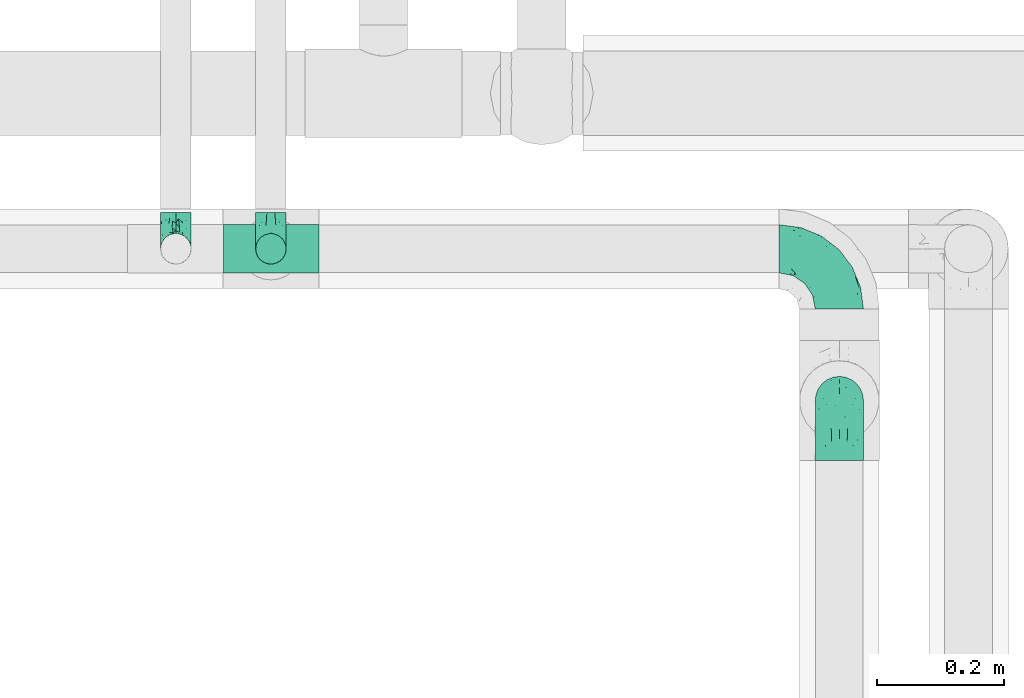
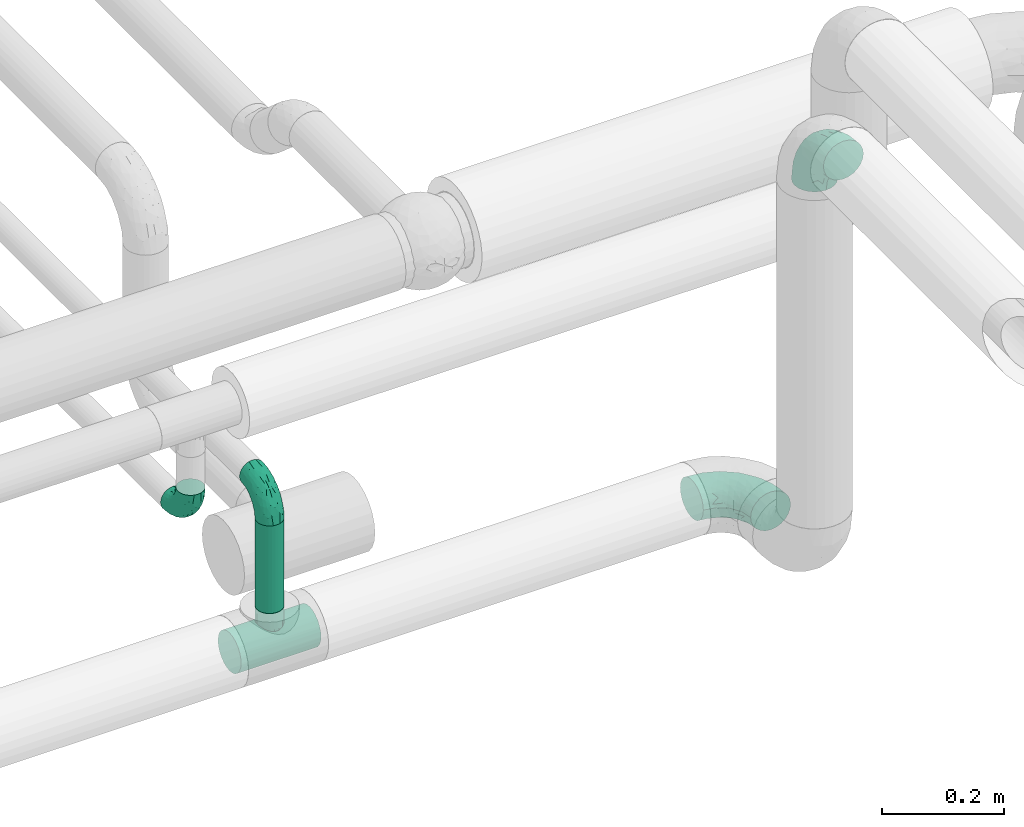
# One storey, part 557 of 824: 5 flow fittings, 1 flow segment.
"""IFC2X3 building model written with IfcOpenShell, lengths in millimetres."""

from ifc_helpers import new_model, entity, si_unit, converted_unit, derived_unit, direction, frame, origin, origin_2d_with_axis, place, context, subcontext, project, spatial, circle, extrude, faceted_brep, source, transform, mapped, material, type_object, type_shapes, element, save


model = new_model("IFC2X3")

# Units and contexts
model_context = context("Model", 3, precision=0.01, world=origin(), true_north=direction((6.12303176911189e-17, 1.0)))
body_context = subcontext(model_context, "Body", "Model", "MODEL_VIEW")
ifc_project = project(units=[si_unit("LENGTHUNIT", "METRE", prefix="MILLI"), si_unit("AREAUNIT", "SQUARE_METRE"), si_unit("VOLUMEUNIT", "CUBIC_METRE"), converted_unit("PLANEANGLEUNIT", "DEGREE", entity("IfcRatioMeasure", 0.0174532925199433), si_unit("PLANEANGLEUNIT", "RADIAN"), dimensions=[0, 0, 0, 0, 0, 0, 0]), si_unit("MASSUNIT", "GRAM", prefix="KILO"), derived_unit("MASSDENSITYUNIT", [(si_unit("MASSUNIT", "GRAM", prefix="KILO"), 1), (si_unit("LENGTHUNIT", "METRE"), -3)]), derived_unit("MOMENTOFINERTIAUNIT", [(si_unit("LENGTHUNIT", "METRE"), 4)]), si_unit("TIMEUNIT", "SECOND"), si_unit("FREQUENCYUNIT", "HERTZ"), si_unit("THERMODYNAMICTEMPERATUREUNIT", "DEGREE_CELSIUS"), derived_unit("THERMALTRANSMITTANCEUNIT", [(si_unit("MASSUNIT", "GRAM", prefix="KILO"), 1), (si_unit("THERMODYNAMICTEMPERATUREUNIT", "KELVIN"), -1), (si_unit("TIMEUNIT", "SECOND"), -3)]), derived_unit("VOLUMETRICFLOWRATEUNIT", [(si_unit("LENGTHUNIT", "METRE"), 3), (si_unit("TIMEUNIT", "SECOND"), -1)]), derived_unit("MASSFLOWRATEUNIT", [(si_unit("MASSUNIT", "GRAM", prefix="KILO"), 1), (si_unit("TIMEUNIT", "SECOND"), -1)]), derived_unit("ROTATIONALFREQUENCYUNIT", [(si_unit("TIMEUNIT", "SECOND"), -1)]), si_unit("ELECTRICCURRENTUNIT", "AMPERE"), si_unit("ELECTRICVOLTAGEUNIT", "VOLT"), si_unit("POWERUNIT", "WATT"), si_unit("FORCEUNIT", "NEWTON", prefix="KILO"), si_unit("ILLUMINANCEUNIT", "LUX"), si_unit("LUMINOUSFLUXUNIT", "LUMEN"), si_unit("LUMINOUSINTENSITYUNIT", "CANDELA"), derived_unit("USERDEFINED", [(si_unit("MASSUNIT", "GRAM", prefix="KILO"), -1), (si_unit("LENGTHUNIT", "METRE"), -2), (si_unit("TIMEUNIT", "SECOND"), 3), (si_unit("LUMINOUSFLUXUNIT", "LUMEN"), 1)]), derived_unit("LINEARVELOCITYUNIT", [(si_unit("LENGTHUNIT", "METRE"), 1), (si_unit("TIMEUNIT", "SECOND"), -1)]), si_unit("PRESSUREUNIT", "PASCAL"), derived_unit("USERDEFINED", [(si_unit("LENGTHUNIT", "METRE"), -2), (si_unit("MASSUNIT", "GRAM", prefix="KILO"), 1), (si_unit("TIMEUNIT", "SECOND"), -2)]), derived_unit("LINEARFORCEUNIT", [(si_unit("MASSUNIT", "GRAM", prefix="KILO"), 1), (si_unit("LENGTHUNIT", "METRE"), 1), (si_unit("TIMEUNIT", "SECOND"), -2), (si_unit("LENGTHUNIT", "METRE"), -1)]), derived_unit("PLANARFORCEUNIT", [(si_unit("MASSUNIT", "GRAM", prefix="KILO"), 1), (si_unit("LENGTHUNIT", "METRE"), 1), (si_unit("TIMEUNIT", "SECOND"), -2), (si_unit("LENGTHUNIT", "METRE"), -2)])], contexts=[model_context])

# Site, building, storey
site_placement = place(None, origin())
site = spatial("IfcSite", under=ifc_project, at=site_placement, CompositionType="ELEMENT")
building_placement = place(site_placement, origin())
building = spatial("IfcBuilding", under=site, at=building_placement, CompositionType="ELEMENT")
storey_placement = place(building_placement, frame((0.0, 0.0, 28200.0)))
storey = spatial("IfcBuildingStorey", under=building, at=storey_placement, CompositionType="ELEMENT", Elevation=28200.0)

# Flow segment
pipe_segment_type = type_object("IfcPipeSegmentType", PredefinedType="NOTDEFINED")
flow_segment_placement = place(storey_placement, frame((25740.61, 12044.41, 2667.0)))
element("IfcFlowSegment", 1, at=flow_segment_placement, inside=storey, type_object=pipe_segment_type, context=body_context, shape_type="SweptSolid", body=[
    extrude(circle(Radius=24.0, at=origin_2d_with_axis()), frame((25.6, 25.6, 0.0)), (0.0, 0.0, 1.0), 175.999999999995),
])

# Flow fittings
ifc_material = material()
pipe_fitting_type_1 = type_object("IfcPipeFittingType", PredefinedType="NOTDEFINED", material=ifc_material)
shared_shape_1 = source(origin(), body_context, "Body", "Brep", [
    faceted_brep([(-76.0, 9.85, -36.75), (-76.0, 0.0, -38.05), (-76.0, -9.85, -36.75), (-76.0, -19.03, -32.95), (-76.0, -26.91, -26.91), (-76.0, -32.95, -19.03), (-76.0, -36.75, -9.85), (-76.0, -38.05, 0.0), (-76.0, -36.75, 9.85), (-76.0, -32.95, 19.02), (-76.0, -26.91, 26.91), (-76.0, -19.03, 32.95), (-76.0, -9.85, 36.75), (-76.0, 0.0, 38.05), (-76.0, 9.85, 36.75), (-76.0, 19.02, 32.95), (-76.0, 26.91, 26.91), (-76.0, 32.95, 19.02), (-76.0, 36.75, 9.85), (-76.0, 38.05, 0.0), (-76.0, 36.75, -9.85), (-76.0, 32.95, -19.03), (-76.0, 26.91, -26.91), (-76.0, 19.02, -32.95), (76.0, 26.91, -26.91), (76.0, 32.95, -19.03), (76.0, 36.75, -9.85), (76.0, 38.05, 0.0), (76.0, 36.75, 9.85), (76.0, 32.95, 19.02), (76.0, 26.91, 26.91), (76.0, 19.02, 32.95), (76.0, 9.85, 36.75), (76.0, 0.0, 38.05), (76.0, -9.85, 36.75), (76.0, -19.03, 32.95), (76.0, -26.91, 26.91), (76.0, -32.95, 19.02), (76.0, -36.75, 9.85), (76.0, -38.05, 0.0), (76.0, -36.75, -9.85), (76.0, -32.95, -19.03), (76.0, -26.91, -26.91), (76.0, -19.03, -32.95), (76.0, -9.85, -36.75), (76.0, 0.0, -38.05), (76.0, 9.85, -36.75), (76.0, 19.02, -32.95), (22.62, -37.1, 8.45), (23.39, -37.58, 4.22), (24.15, -38.05, 0.0), (18.42, -34.7, 15.61), (4.31, -29.72, 23.76), (12.18, -31.83, 20.86), (8.24, -30.77, 22.31), (-24.15, -38.05, 0.0), (-23.39, -37.58, 4.22), (-22.63, -37.1, 8.44), (-18.43, -34.7, 15.61), (-12.18, -31.83, 20.85), (-4.31, -29.72, 23.76), (0.0, -29.72, 23.76), (4.31, -29.72, -23.76), (12.18, -31.83, -20.86), (8.24, -30.77, -22.31), (18.42, -34.7, -15.61), (22.62, -37.1, -8.45), (23.39, -37.58, -4.22), (-4.31, -29.72, -23.76), (-12.18, -31.83, -20.85), (-18.43, -34.7, -15.61), (0.0, -29.72, -23.76), (-22.63, -37.1, -8.44), (-23.39, -37.58, -4.22), (0.0, -67.0, -24.15), (6.25, -67.0, -23.33), (12.08, -67.0, -20.91), (17.08, -67.0, -17.08), (20.91, -67.0, -12.08), (23.33, -67.0, -6.25), (24.15, -67.0, 0.0), (23.33, -67.0, 6.25), (20.91, -67.0, 12.07), (17.08, -67.0, 17.08), (12.08, -67.0, 20.91), (6.25, -67.0, 23.33), (0.0, -67.0, 24.15), (-6.25, -67.0, 23.33), (-12.07, -67.0, 20.91), (-17.08, -67.0, 17.08), (-20.91, -67.0, 12.07), (-23.33, -67.0, 6.25), (-24.15, -67.0, 0.0), (-23.33, -67.0, -6.25), (-20.91, -67.0, -12.08), (-17.08, -67.0, -17.08), (-12.07, -67.0, -20.91), (-6.25, -67.0, -23.33)], [[[0, 1, 2, 3, 4, 5, 6, 7, 8, 9, 10, 11, 12, 13, 14, 15, 16, 17, 18, 19, 20, 21, 22, 23]], [[24, 25, 26, 27, 28, 29, 30, 31, 32, 33, 34, 35, 36, 37, 38, 39, 40, 41, 42, 43, 44, 45, 46, 47]], [[39, 38, 48]], [[39, 48, 49, 50]], [[38, 51, 48]], [[37, 36, 52]], [[53, 51, 37]], [[37, 52, 54, 53]], [[36, 10, 52]], [[37, 51, 38]], [[7, 55, 56, 57]], [[8, 7, 57]], [[57, 58, 8]], [[59, 60, 9]], [[59, 9, 58]], [[9, 60, 10]], [[58, 9, 8]], [[10, 60, 61, 52]], [[36, 35, 11, 10]], [[13, 12, 34, 33]], [[12, 11, 35, 34]], [[14, 13, 33, 32]], [[29, 28, 18, 17]], [[16, 15, 31, 30]], [[17, 16, 30, 29]], [[32, 31, 15, 14]], [[19, 18, 28, 27]], [[26, 25, 21, 20]], [[25, 24, 22, 21]], [[27, 26, 20, 19]], [[45, 44, 2, 1]], [[0, 23, 47, 46]], [[1, 0, 46, 45]], [[24, 47, 23, 22]], [[3, 2, 44, 43]], [[43, 42, 4, 3]], [[42, 41, 62]], [[41, 63, 64, 62]], [[41, 65, 63]], [[42, 62, 4]], [[40, 39, 66]], [[66, 65, 40]], [[39, 50, 67, 66]], [[40, 65, 41]], [[68, 69, 5]], [[5, 4, 68]], [[69, 70, 5]], [[4, 62, 71, 68]], [[70, 72, 6]], [[72, 7, 6]], [[7, 72, 73, 55]], [[70, 6, 5]], [[74, 75, 76, 77, 78, 79, 80, 81, 82, 83, 84, 85, 86, 87, 88, 89, 90, 91, 92, 93, 94, 95, 96, 97]], [[56, 92, 91]], [[86, 60, 87]], [[59, 89, 88]], [[84, 54, 85]], [[49, 80, 50]], [[59, 88, 87]], [[49, 48, 81]], [[91, 57, 56]], [[55, 92, 56]], [[57, 91, 90]], [[57, 90, 58]], [[89, 58, 90]], [[89, 59, 58]], [[87, 60, 59]], [[86, 52, 61, 60]], [[84, 53, 54]], [[83, 53, 84]], [[48, 82, 81]], [[83, 82, 51]], [[52, 86, 85]], [[54, 52, 85]], [[53, 83, 51]], [[51, 82, 48]], [[80, 49, 81]], [[79, 67, 80]], [[77, 65, 78]], [[64, 76, 75]], [[79, 66, 67]], [[78, 66, 79]], [[63, 77, 76]], [[67, 50, 80]], [[66, 78, 65]], [[75, 62, 64]], [[63, 65, 77]], [[74, 68, 71, 62]], [[74, 62, 75]], [[73, 92, 55]], [[69, 97, 96]], [[73, 72, 93]], [[95, 69, 96]], [[72, 94, 93]], [[95, 94, 70]], [[68, 74, 97]], [[97, 69, 68]], [[69, 95, 70]], [[70, 94, 72]], [[92, 73, 93]], [[64, 63, 76]]]),
])
type_shapes(pipe_fitting_type_1, [shared_shape_1])
flow_fitting_placement = place(storey_placement, frame((25766.21, 12070.0, 2600.0), z_axis=(0.0, 1.0, 0.0), x_axis=(1.0, 0.0, 0.0)))
element("IfcFlowFitting", 2, at=flow_fitting_placement, inside=storey, type_object=pipe_fitting_type_1, material=ifc_material, context=body_context, shape_type="MappedRepresentation", body=[
    mapped(shared_shape_1, transform((0.0, 0.0, 0.0), scale=1.0)),
])
pipe_fitting_type_2 = type_object("IfcPipeFittingType", PredefinedType="NOTDEFINED", material=ifc_material)
shared_shape_2 = source(origin(), body_context, "Body", "Brep", [
    faceted_brep([(-57.0, 12.07, -20.91), (-57.0, 6.25, -23.33), (-57.0, 0.0, -24.15), (-57.0, -6.25, -23.33), (-57.0, -12.08, -20.91), (-57.0, -17.08, -17.08), (-57.0, -20.91, -12.08), (-57.0, -23.33, -6.25), (-57.0, -24.15, 0.0), (-57.0, -23.33, 6.25), (-57.0, -20.91, 12.07), (-57.0, -17.08, 17.08), (-57.0, -12.08, 20.91), (-57.0, -6.25, 23.33), (-57.0, 0.0, 24.15), (-57.0, 6.25, 23.33), (-57.0, 12.07, 20.91), (-57.0, 17.08, 17.08), (-57.0, 20.91, 12.07), (-57.0, 23.33, 6.25), (-57.0, 24.15, 0.0), (-57.0, 23.33, -6.25), (-57.0, 20.91, -12.08), (-57.0, 17.08, -17.08), (0.0, 57.0, -24.15), (-6.25, 57.0, -23.33), (-12.07, 57.0, -20.91), (-17.08, 57.0, -17.08), (-20.91, 57.0, -12.08), (-23.33, 57.0, -6.25), (-24.15, 57.0, 0.0), (-23.33, 57.0, 6.25), (-20.91, 57.0, 12.07), (-17.08, 57.0, 17.08), (-12.07, 57.0, 20.91), (-6.25, 57.0, 23.33), (0.0, 57.0, 24.15), (6.25, 57.0, 23.33), (12.08, 57.0, 20.91), (17.08, 57.0, 17.08), (20.91, 57.0, 12.07), (23.33, 57.0, 6.25), (24.15, 57.0, 0.0), (23.33, 57.0, -6.25), (20.91, 57.0, -12.08), (17.08, 57.0, -17.08), (12.08, 57.0, -20.91), (6.25, 57.0, -23.33), (14.9, 21.14, 6.17), (13.61, 24.64, 12.48), (6.23, 8.95, 8.98), (-41.47, -21.06, 0.0), (-41.92, -18.38, 13.72), (-24.64, -13.61, 12.48), (-37.37, -13.24, 18.15), (-6.8, -4.93, 8.18), (-21.76, -15.19, 6.22), (-12.78, -9.18, 0.0), (-37.73, -20.51, 7.75), (-7.38, 7.38, 20.24), (-23.37, -4.26, 20.42), (-11.9, -3.19, 15.86), (-42.14, -8.7, 21.82), (13.24, 37.37, 18.15), (9.33, 23.53, 16.85), (4.26, 23.37, 20.42), (2.77, 10.92, 15.55), (-29.46, 0.91, 23.52), (-44.13, 20.56, 15.69), (-39.25, 26.33, 10.88), (-49.02, 22.92, 9.96), (-34.58, 23.87, 17.15), (-15.8, 6.8, 22.81), (-8.67, 20.47, 23.88), (-18.12, 12.9, 24.08), (-48.29, 14.92, 19.65), (-44.06, -2.85, 23.78), (-9.23, 48.95, 22.58), (-3.78, 42.74, 24.07), (-40.34, 4.26, 24.09), (-44.02, 26.14, 5.46), (-44.04, 9.88, 22.74), (-4.95, 16.87, 22.52), (-2.75, 1.43, 12.5), (-25.48, 40.98, 10.71), (20.51, 37.73, 7.75), (18.38, 41.92, 13.72), (8.7, 42.14, 21.82), (-25.95, -17.97, 0.0), (2.85, 44.06, 23.78), (21.06, 41.47, 0.0), (17.97, 25.95, 0.0), (-24.04, -9.27, 17.13), (-33.26, 33.26, 5.86), (-28.55, 40.57, 0.0), (-40.57, 28.55, 0.0), (-25.29, 47.19, 4.06), (-27.01, 31.1, 16.77), (-15.7, 43.95, 19.9), (-20.27, 45.22, 15.61), (-30.53, 31.98, 12.64), (-11.28, 38.33, 22.92), (-9.97, 27.88, 24.09), (-20.15, 30.26, 21.25), (-31.25, 11.75, 23.64), (-28.75, 7.23, 24.15), (-29.53, 18.06, 22.27), (-28.44, 24.21, 20.02), (-37.55, 17.7, 20.26), (-15.88, 29.25, 22.99), (-20.82, 20.82, 23.44), (-0.91, 29.46, 23.52), (-13.5, -7.67, 12.04), (1.49, 1.56, 5.16), (8.86, 10.35, 4.59), (0.38, -0.38, 0.0), (9.18, 12.78, 0.0), (-37.37, -13.24, -18.15), (8.86, 10.35, -4.59), (-45.22, 20.27, -15.61), (-43.95, 15.7, -19.9), (-38.33, 11.28, -22.92), (-48.95, 9.23, -22.58), (-47.19, 25.29, -4.06), (-33.26, 33.26, -5.86), (18.38, 41.92, -13.72), (-30.26, 20.15, -21.25), (2.85, 44.06, -23.78), (-4.26, 40.34, -24.09), (-40.98, 25.48, -10.71), (-41.92, -18.38, -13.72), (9.25, 23.5, -16.92), (4.26, 23.37, -20.42), (13.24, 37.37, -18.15), (-37.73, -20.51, -7.75), (-11.75, 31.25, -23.64), (-7.23, 28.75, -24.15), (-12.9, 18.12, -24.08), (8.7, 42.14, -21.82), (-44.06, -2.85, -23.78), (-6.8, 15.8, -22.81), (-20.47, 8.67, -23.88), (-24.64, -13.61, -12.48), (-42.74, 3.78, -24.07), (-18.06, 29.53, -22.27), (-24.21, 28.44, -20.02), (-27.88, 9.97, -24.09), (-31.1, 27.01, -16.77), (-26.14, 44.02, -5.46), (14.9, 21.14, -6.17), (20.51, 37.73, -7.75), (-9.88, 44.04, -22.74), (-20.56, 44.13, -15.69), (-21.76, -15.19, -6.22), (-13.5, -7.67, -12.04), (-24.14, -9.76, -16.74), (-11.9, -3.19, -15.86), (-14.92, 48.29, -19.65), (-23.37, -4.26, -20.42), (-0.91, 29.46, -23.52), (-26.33, 39.25, -10.88), (-23.87, 34.58, -17.15), (-42.14, -8.7, -21.82), (-22.92, 49.02, -9.96), (13.61, 24.64, -12.48), (-31.98, 30.53, -12.64), (-16.87, 4.95, -22.52), (-17.7, 37.55, -20.26), (-29.25, 15.88, -22.99), (-20.82, 20.82, -23.44), (-29.46, 0.91, -23.52), (-7.38, 7.38, -20.24), (2.77, 10.92, -15.55), (6.23, 8.95, -8.98), (-6.8, -4.93, -8.18), (-2.81, 1.41, -12.54), (1.49, 1.56, -5.16)], [[[0, 1, 2, 3, 4, 5, 6, 7, 8, 9, 10, 11, 12, 13, 14, 15, 16, 17, 18, 19, 20, 21, 22, 23]], [[24, 25, 26, 27, 28, 29, 30, 31, 32, 33, 34, 35, 36, 37, 38, 39, 40, 41, 42, 43, 44, 45, 46, 47]], [[48, 49, 50]], [[9, 8, 51]], [[52, 53, 54]], [[55, 56, 57]], [[10, 58, 52]], [[9, 58, 10]], [[59, 60, 61]], [[54, 12, 11]], [[54, 62, 12]], [[63, 39, 38]], [[64, 65, 66]], [[62, 60, 67]], [[68, 69, 70]], [[71, 69, 68]], [[72, 73, 74]], [[16, 75, 17]], [[13, 76, 14]], [[35, 77, 78]], [[14, 79, 15]], [[17, 68, 18]], [[14, 76, 79]], [[20, 19, 80]], [[70, 19, 18]], [[81, 15, 79]], [[15, 81, 16]], [[73, 72, 82]], [[66, 83, 50]], [[32, 31, 84]], [[85, 86, 49]], [[63, 87, 65]], [[56, 58, 88]], [[36, 89, 37]], [[85, 41, 40]], [[36, 35, 78]], [[90, 41, 85]], [[40, 39, 86]], [[12, 62, 13]], [[86, 85, 40]], [[48, 85, 49]], [[85, 91, 90]], [[87, 38, 37]], [[92, 60, 54]], [[80, 69, 93]], [[93, 94, 95]], [[10, 52, 11]], [[94, 96, 30]], [[97, 98, 99]], [[80, 93, 95]], [[100, 97, 84]], [[99, 98, 33]], [[101, 102, 78]], [[103, 101, 98]], [[96, 31, 30]], [[77, 98, 101]], [[77, 35, 34]], [[34, 33, 98]], [[9, 51, 58]], [[87, 63, 38]], [[104, 105, 74]], [[106, 103, 107]], [[106, 81, 104]], [[75, 68, 17]], [[108, 107, 71]], [[33, 32, 99]], [[109, 103, 110]], [[101, 109, 102]], [[89, 78, 111]], [[53, 52, 58]], [[54, 11, 52]], [[60, 62, 54]], [[88, 58, 51]], [[76, 62, 67]], [[53, 112, 92]], [[60, 59, 72]], [[39, 63, 86]], [[49, 86, 63]], [[89, 87, 37]], [[42, 41, 90]], [[111, 82, 65]], [[111, 65, 87]], [[65, 59, 66]], [[104, 81, 79]], [[75, 81, 108]], [[32, 84, 99]], [[97, 99, 84]], [[98, 97, 103]], [[106, 107, 108]], [[74, 102, 110]], [[111, 78, 102]], [[74, 110, 104]], [[74, 67, 72]], [[61, 92, 112]], [[66, 59, 61]], [[56, 53, 58]], [[66, 50, 49]], [[61, 112, 83]], [[66, 49, 64]], [[78, 89, 36]], [[87, 89, 111]], [[62, 76, 13]], [[79, 76, 67]], [[100, 93, 69]], [[96, 93, 84]], [[55, 113, 50]], [[113, 114, 50]], [[104, 79, 105]], [[106, 104, 110]], [[20, 80, 95]], [[85, 48, 91]], [[115, 114, 113]], [[116, 91, 48]], [[70, 80, 19]], [[93, 96, 94]], [[84, 31, 96]], [[103, 106, 110]], [[81, 106, 108]], [[103, 97, 107]], [[71, 107, 97]], [[71, 97, 100]], [[108, 71, 68]], [[79, 67, 105]], [[67, 74, 105]], [[115, 113, 57]], [[112, 56, 55]], [[56, 88, 57]], [[60, 72, 67]], [[82, 72, 59]], [[65, 82, 59]], [[82, 111, 73]], [[111, 102, 73]], [[102, 74, 73]], [[81, 75, 16]], [[68, 75, 108]], [[68, 70, 18]], [[80, 70, 69]], [[98, 77, 34]], [[78, 77, 101]], [[93, 100, 84]], [[71, 100, 69]], [[102, 109, 110]], [[101, 103, 109]], [[53, 92, 54]], [[61, 60, 92]], [[56, 112, 53]], [[83, 112, 55]], [[50, 83, 55]], [[61, 83, 66]], [[49, 63, 64]], [[65, 64, 63]], [[57, 113, 55]], [[114, 115, 116]], [[116, 48, 114]], [[48, 50, 114]], [[117, 5, 4]], [[116, 115, 118]], [[119, 120, 23]], [[121, 122, 120]], [[95, 123, 20]], [[0, 23, 120]], [[124, 95, 94]], [[125, 45, 44]], [[121, 120, 126]], [[24, 127, 128]], [[22, 21, 129]], [[0, 122, 1]], [[5, 117, 130]], [[131, 132, 133]], [[134, 88, 51]], [[135, 136, 137]], [[6, 5, 130]], [[46, 138, 47]], [[139, 3, 2]], [[140, 141, 137]], [[6, 134, 7]], [[134, 130, 142]], [[143, 2, 1]], [[144, 126, 145]], [[121, 146, 143]], [[147, 120, 119]], [[94, 148, 124]], [[149, 150, 91]], [[30, 29, 148]], [[151, 25, 128]], [[27, 152, 28]], [[134, 153, 88]], [[154, 155, 156]], [[27, 26, 157]], [[151, 26, 25]], [[155, 158, 156]], [[24, 47, 127]], [[1, 122, 143]], [[138, 132, 159]], [[160, 152, 161]], [[24, 128, 25]], [[46, 133, 138]], [[162, 117, 4]], [[148, 160, 124]], [[152, 160, 163]], [[154, 142, 155]], [[45, 125, 133]], [[133, 46, 45]], [[125, 164, 133]], [[51, 7, 134]], [[42, 90, 43]], [[165, 147, 129]], [[153, 134, 142]], [[43, 150, 44]], [[162, 4, 3]], [[141, 140, 166]], [[117, 162, 158]], [[163, 29, 28]], [[43, 90, 150]], [[123, 21, 20]], [[144, 151, 135]], [[157, 152, 27]], [[167, 145, 161]], [[23, 22, 119]], [[168, 126, 169]], [[121, 168, 146]], [[139, 143, 170]], [[142, 130, 117]], [[8, 7, 51]], [[134, 6, 130]], [[139, 162, 3]], [[170, 166, 158]], [[170, 158, 162]], [[158, 171, 156]], [[44, 150, 125]], [[91, 150, 90]], [[164, 125, 150]], [[132, 138, 133]], [[127, 138, 159]], [[131, 164, 172]], [[132, 171, 140]], [[135, 151, 128]], [[157, 151, 167]], [[22, 129, 119]], [[147, 119, 129]], [[120, 147, 126]], [[144, 145, 167]], [[137, 146, 169]], [[170, 143, 146]], [[137, 169, 135]], [[137, 159, 140]], [[171, 172, 156]], [[173, 174, 175]], [[156, 175, 154]], [[174, 57, 153]], [[132, 172, 171]], [[172, 164, 173]], [[143, 139, 2]], [[162, 139, 170]], [[138, 127, 47]], [[128, 127, 159]], [[165, 124, 160]], [[123, 124, 129]], [[149, 173, 164]], [[176, 174, 173]], [[135, 128, 136]], [[144, 135, 169]], [[150, 149, 164]], [[176, 118, 115]], [[149, 91, 116]], [[30, 148, 94]], [[163, 148, 29]], [[124, 123, 95]], [[129, 21, 123]], [[126, 144, 169]], [[151, 144, 167]], [[126, 147, 145]], [[161, 145, 147]], [[161, 147, 165]], [[167, 161, 152]], [[128, 159, 136]], [[159, 137, 136]], [[154, 153, 142]], [[132, 140, 159]], [[174, 176, 57]], [[57, 88, 153]], [[166, 140, 171]], [[158, 166, 171]], [[166, 170, 141]], [[170, 146, 141]], [[146, 137, 141]], [[151, 157, 26]], [[152, 157, 167]], [[152, 163, 28]], [[148, 163, 160]], [[120, 122, 0]], [[143, 122, 121]], [[124, 165, 129]], [[161, 165, 160]], [[146, 168, 169]], [[121, 126, 168]], [[142, 117, 155]], [[158, 155, 117]], [[175, 156, 172]], [[153, 154, 174]], [[173, 175, 172]], [[174, 154, 175]], [[164, 131, 133]], [[172, 132, 131]], [[176, 173, 118]], [[57, 176, 115]], [[173, 149, 118]], [[149, 116, 118]]]),
])
type_shapes(pipe_fitting_type_2, [shared_shape_2])
for number, where, z_axis, x_axis in (
    (3, (25616.18, 12070.0, 2900.0), (1.0, 0.0, 0.0), (0.0, 0.0, -1.0)),
    (4, (25766.21, 12070.0, 2900.0), (-1.0, 0.0, 0.0), (0.0, 0.0, 1.0)),
):
    element("IfcFlowFitting", number, at=place(storey_placement, frame(where, z_axis=z_axis, x_axis=x_axis)), inside=storey, type_object=pipe_fitting_type_2, material=ifc_material, context=body_context, shape_type="MappedRepresentation", body=[
        mapped(shared_shape_2, transform((0.0, 0.0, 0.0), scale=1.0)),
    ])
pipe_fitting_type_3 = type_object("IfcPipeFittingType", PredefinedType="NOTDEFINED", material=ifc_material)
shared_shape_3 = source(origin(), body_context, "Body", "Brep", [
    faceted_brep([(-95.0, 19.02, -32.95), (-95.0, 9.85, -36.75), (-95.0, 0.0, -38.05), (-95.0, -9.85, -36.75), (-95.0, -19.03, -32.95), (-95.0, -26.91, -26.91), (-95.0, -32.95, -19.03), (-95.0, -36.75, -9.85), (-95.0, -38.05, 0.0), (-95.0, -36.75, 9.85), (-95.0, -32.95, 19.02), (-95.0, -26.91, 26.91), (-95.0, -19.03, 32.95), (-95.0, -9.85, 36.75), (-95.0, 0.0, 38.05), (-95.0, 9.85, 36.75), (-95.0, 19.02, 32.95), (-95.0, 26.91, 26.91), (-95.0, 32.95, 19.02), (-95.0, 36.75, 9.85), (-95.0, 38.05, 0.0), (-95.0, 36.75, -9.85), (-95.0, 32.95, -19.03), (-95.0, 26.91, -26.91), (0.0, 95.0, -38.05), (-9.85, 95.0, -36.75), (-19.02, 95.0, -32.95), (-26.91, 95.0, -26.91), (-32.95, 95.0, -19.03), (-36.75, 95.0, -9.85), (-38.05, 95.0, 0.0), (-36.75, 95.0, 9.85), (-32.95, 95.0, 19.02), (-26.91, 95.0, 26.91), (-19.02, 95.0, 32.95), (-9.85, 95.0, 36.75), (0.0, 95.0, 38.05), (9.85, 95.0, 36.75), (19.03, 95.0, 32.95), (26.91, 95.0, 26.91), (32.95, 95.0, 19.02), (36.75, 95.0, 9.85), (38.05, 95.0, 0.0), (36.75, 95.0, -9.85), (32.95, 95.0, -19.03), (26.91, 95.0, -26.91), (19.03, 95.0, -32.95), (9.85, 95.0, -36.75), (-7.99, -4.96, 6.3), (-0.92, 0.92, 0.0), (4.62, 8.1, 8.01), (-76.19, -35.57, 0.0), (-64.32, -32.32, 12.43), (20.51, 62.45, 28.68), (-60.56, -33.52, 0.0), (-70.4, -13.47, 34.42), (-39.61, -5.88, 32.32), (-49.6, 2.07, 37.1), (-70.34, -28.81, 21.71), (14.64, 40.81, 26.5), (5.88, 39.61, 32.32), (3.59, 20.77, 25.31), (-40.45, 68.06, 16.75), (-62.45, -20.51, 28.68), (-44.52, -26.87, 0.0), (-28.47, -20.22, 0.0), (-26.43, -17.83, 8.75), (-76.1, 39.63, 10.76), (-72.74, 37.58, 18.19), (-60.35, 46.18, 14.61), (-13.4, 13.4, 32.12), (-20.77, -3.59, 25.31), (-14.66, 81.47, 35.56), (-6.22, 71.26, 37.92), (-57.5, 42.48, 22.79), (-15.0, 34.74, 37.7), (-27.1, 12.08, 36.05), (-9.2, 28.81, 35.63), (-79.98, 23.7, 30.95), (-73.68, -4.3, 37.48), (-30.74, 21.67, 37.97), (-62.36, 47.59, 6.79), (-72.71, 32.83, 24.69), (-67.42, 7.02, 37.95), (-32.13, 75.27, 24.51), (-43.46, 51.47, 26.26), (-24.98, 73.15, 31.29), (20.59, 41.28, 19.85), (7.79, 16.09, 15.86), (-73.21, 42.39, 0.0), (-54.73, 54.73, 0.0), (-73.44, 15.79, 35.79), (-5.94, 4.32, 20.43), (28.81, 70.34, 21.71), (32.32, 64.32, 12.43), (-53.59, 26.2, 35.09), (-52.02, 19.31, 37.21), (21.38, 33.53, 10.34), (26.87, 44.52, 0.0), (-48.28, 12.14, 38.05), (4.3, 73.68, 37.48), (-44.08, -25.52, 12.79), (-41.28, -20.59, 19.85), (35.57, 76.19, 0.0), (-47.26, 54.3, 20.18), (-47.4, 61.99, 8.58), (-42.39, 73.21, 0.0), (-39.67, 78.86, 7.21), (-45.69, 36.84, 33.11), (-32.83, 50.13, 33.35), (13.47, 70.4, 34.42), (-18.25, 63.73, 36.07), (-40.63, -13.75, 27.22), (-16.63, 46.37, 37.95), (-53.47, 38.79, 28.59), (-26.07, 48.54, 36.15), (-34.51, 34.51, 36.86), (-2.07, 49.6, 37.1), (-22.79, -10.49, 19.23), (-61.73, 28.67, 31.87), (9.65, 14.7, 0.0), (20.22, 28.47, 0.0), (33.52, 60.56, 0.0), (-11.42, -5.44, 13.25), (-14.7, -9.65, 0.0), (-81.47, 14.66, -35.56), (-62.45, -20.51, -28.68), (-71.26, 6.22, -37.92), (-75.27, 32.13, -24.51), (-73.15, 24.98, -31.29), (13.47, 70.4, -34.42), (5.88, 39.61, -32.32), (-2.07, 49.6, -37.1), (-78.86, 39.67, -7.21), (-70.4, -13.47, -34.42), (-39.61, -5.88, -32.32), (-61.99, 47.4, -8.58), (32.32, 64.32, -12.43), (28.81, 70.34, -21.71), (-63.73, 18.25, -36.07), (-50.13, 32.83, -33.35), (4.3, 73.68, -37.48), (-7.02, 67.42, -37.95), (-39.63, 76.1, -10.76), (-46.18, 60.35, -14.61), (-47.59, 62.36, -6.79), (-64.32, -32.32, -12.43), (-26.2, 53.59, -35.09), (-15.79, 73.44, -35.79), (-19.31, 52.02, -37.21), (-37.58, 72.74, -18.19), (-70.34, -28.81, -21.71), (-42.48, 57.5, -22.79), (-38.79, 53.47, -28.59), (-51.47, 43.46, -26.26), (-32.83, 72.71, -24.69), (-46.37, 16.63, -37.95), (-73.68, -4.3, -37.48), (-41.28, -20.59, -19.85), (-44.08, -25.52, -12.79), (13.75, 40.63, -27.22), (20.51, 62.45, -28.68), (-68.06, 40.45, -16.75), (-54.3, 47.26, -20.18), (-12.14, 48.28, -38.05), (-21.67, 30.74, -37.97), (-36.84, 45.69, -33.11), (-11.42, -5.44, -13.25), (7.79, 16.09, -15.86), (4.62, 8.1, -8.01), (-23.7, 79.98, -30.95), (-26.43, -17.83, -8.75), (-7.99, -4.96, -6.3), (-40.81, -14.64, -26.5), (-20.77, -3.59, -25.31), (-34.74, 15.0, -37.7), (-12.08, 27.1, -36.05), (-28.81, 9.2, -35.63), (-22.79, -10.49, -19.23), (21.38, 33.53, -10.34), (20.59, 41.28, -19.85), (-48.54, 26.07, -36.15), (-49.6, 2.07, -37.1), (-13.4, 13.4, -32.12), (3.59, 20.77, -25.31), (-28.67, 61.73, -31.87), (-34.51, 34.51, -36.86), (-5.94, 4.32, -20.43)], [[[0, 1, 2, 3, 4, 5, 6, 7, 8, 9, 10, 11, 12, 13, 14, 15, 16, 17, 18, 19, 20, 21, 22, 23]], [[24, 25, 26, 27, 28, 29, 30, 31, 32, 33, 34, 35, 36, 37, 38, 39, 40, 41, 42, 43, 44, 45, 46, 47]], [[48, 49, 50]], [[51, 52, 9]], [[53, 39, 38]], [[9, 52, 10]], [[54, 52, 51]], [[55, 56, 57]], [[11, 10, 58]], [[59, 60, 61]], [[32, 31, 62]], [[63, 12, 11]], [[63, 55, 12]], [[64, 65, 66]], [[67, 68, 69]], [[70, 56, 71]], [[35, 72, 73]], [[69, 68, 74]], [[75, 76, 77]], [[16, 78, 17]], [[13, 79, 14]], [[76, 75, 80]], [[67, 69, 81]], [[18, 17, 82]], [[14, 79, 83]], [[20, 19, 67]], [[84, 85, 86]], [[87, 61, 88]], [[89, 81, 90]], [[18, 82, 68]], [[15, 91, 16]], [[14, 83, 15]], [[71, 92, 61]], [[17, 78, 82]], [[93, 87, 94]], [[95, 91, 96]], [[97, 98, 94]], [[86, 72, 34]], [[96, 99, 80]], [[37, 36, 100]], [[40, 39, 93]], [[40, 94, 41]], [[64, 66, 101]], [[93, 94, 40]], [[58, 102, 63]], [[94, 103, 41]], [[94, 87, 97]], [[104, 69, 74]], [[34, 33, 86]], [[105, 69, 104]], [[52, 58, 10]], [[106, 107, 30]], [[108, 109, 85]], [[105, 106, 90]], [[53, 110, 60]], [[86, 111, 72]], [[86, 109, 111]], [[33, 84, 86]], [[12, 55, 13]], [[112, 56, 63]], [[110, 38, 37]], [[34, 72, 35]], [[36, 35, 73]], [[111, 113, 73]], [[105, 107, 106]], [[110, 53, 38]], [[74, 114, 85]], [[91, 15, 83]], [[105, 90, 81]], [[107, 62, 31]], [[33, 32, 84]], [[115, 109, 116]], [[111, 115, 113]], [[100, 73, 117]], [[56, 55, 63]], [[79, 55, 57]], [[102, 118, 112]], [[56, 70, 76]], [[100, 110, 37]], [[117, 77, 60]], [[117, 60, 110]], [[60, 70, 61]], [[58, 52, 101]], [[63, 11, 58]], [[39, 53, 93]], [[87, 93, 53]], [[96, 91, 83]], [[78, 91, 119]], [[32, 62, 84]], [[84, 62, 104]], [[86, 85, 109]], [[85, 114, 108]], [[80, 113, 116]], [[117, 73, 113]], [[80, 116, 96]], [[80, 57, 76]], [[71, 112, 118]], [[61, 87, 59]], [[62, 107, 105]], [[97, 120, 121]], [[70, 71, 61]], [[71, 118, 92]], [[73, 100, 36]], [[110, 100, 117]], [[55, 79, 13]], [[83, 79, 57]], [[96, 83, 99]], [[116, 108, 95]], [[50, 97, 88]], [[97, 87, 88]], [[50, 49, 120]], [[122, 94, 98]], [[89, 20, 67]], [[105, 81, 69]], [[89, 67, 81]], [[68, 19, 18]], [[68, 67, 19]], [[74, 68, 82]], [[114, 82, 119]], [[74, 85, 104]], [[82, 114, 74]], [[114, 119, 108]], [[95, 108, 119]], [[116, 109, 108]], [[123, 48, 50]], [[97, 50, 120]], [[123, 50, 88]], [[91, 95, 119]], [[116, 95, 96]], [[84, 104, 85]], [[104, 62, 105]], [[83, 57, 99]], [[57, 80, 99]], [[66, 48, 123]], [[66, 124, 48]], [[118, 66, 123]], [[124, 66, 65]], [[66, 118, 101]], [[54, 64, 52]], [[124, 49, 48]], [[30, 107, 31]], [[91, 78, 16]], [[82, 78, 119]], [[56, 76, 57]], [[77, 76, 70]], [[60, 77, 70]], [[77, 117, 75]], [[117, 113, 75]], [[113, 80, 75]], [[9, 8, 51]], [[103, 94, 122]], [[103, 42, 41]], [[73, 72, 111]], [[113, 115, 116]], [[111, 109, 115]], [[102, 112, 63]], [[71, 56, 112]], [[118, 102, 101]], [[92, 123, 88]], [[123, 92, 118]], [[61, 92, 88]], [[87, 53, 59]], [[60, 59, 53]], [[97, 121, 98]], [[58, 101, 102]], [[64, 101, 52]], [[125, 1, 0]], [[126, 5, 4]], [[2, 1, 127]], [[1, 125, 127]], [[128, 129, 23]], [[130, 131, 132]], [[89, 133, 20]], [[126, 134, 135]], [[136, 89, 90]], [[137, 138, 44]], [[139, 129, 140]], [[24, 141, 142]], [[143, 144, 145]], [[125, 129, 139]], [[6, 146, 7]], [[147, 148, 149]], [[146, 51, 7]], [[143, 150, 144]], [[146, 6, 151]], [[152, 153, 154]], [[126, 4, 134]], [[0, 23, 129]], [[28, 155, 150]], [[43, 42, 103]], [[54, 146, 64]], [[139, 156, 127]], [[157, 3, 2]], [[151, 158, 159]], [[160, 131, 161]], [[22, 21, 162]], [[136, 144, 163]], [[149, 164, 165]], [[24, 142, 25]], [[166, 140, 154]], [[154, 129, 128]], [[143, 30, 29]], [[167, 168, 169]], [[155, 28, 27]], [[26, 170, 27]], [[171, 167, 172]], [[26, 25, 148]], [[27, 170, 155]], [[173, 135, 174]], [[144, 150, 152]], [[175, 176, 177]], [[24, 47, 141]], [[45, 161, 46]], [[148, 25, 142]], [[176, 175, 165]], [[64, 159, 171]], [[138, 45, 44]], [[130, 46, 161]], [[137, 44, 43]], [[178, 159, 158]], [[137, 103, 122]], [[163, 144, 152]], [[136, 133, 89]], [[103, 137, 43]], [[6, 5, 151]], [[178, 158, 173]], [[134, 4, 3]], [[178, 173, 174]], [[137, 98, 179]], [[145, 90, 106]], [[138, 180, 161]], [[46, 130, 47]], [[136, 90, 145]], [[133, 162, 21]], [[23, 22, 128]], [[139, 140, 181]], [[139, 181, 156]], [[157, 127, 182]], [[157, 134, 3]], [[182, 177, 135]], [[182, 135, 134]], [[135, 183, 174]], [[131, 130, 161]], [[141, 130, 132]], [[160, 180, 184]], [[131, 183, 176]], [[5, 126, 151]], [[158, 151, 126]], [[180, 138, 137]], [[161, 45, 138]], [[149, 148, 142]], [[170, 148, 185]], [[22, 162, 128]], [[128, 162, 163]], [[129, 154, 140]], [[154, 153, 166]], [[165, 156, 186]], [[182, 127, 156]], [[165, 186, 149]], [[165, 132, 176]], [[131, 184, 183]], [[187, 167, 178]], [[184, 168, 187]], [[167, 169, 172]], [[184, 180, 168]], [[174, 183, 184]], [[127, 157, 2]], [[134, 157, 182]], [[130, 141, 47]], [[142, 141, 132]], [[149, 142, 164]], [[186, 166, 147]], [[180, 179, 168]], [[169, 179, 120]], [[137, 179, 180]], [[179, 121, 120]], [[106, 30, 143]], [[136, 145, 144]], [[106, 143, 145]], [[150, 29, 28]], [[150, 143, 29]], [[152, 150, 155]], [[153, 155, 185]], [[152, 154, 163]], [[155, 153, 152]], [[153, 185, 166]], [[147, 166, 185]], [[186, 140, 166]], [[169, 120, 49]], [[169, 49, 172]], [[179, 169, 168]], [[148, 147, 185]], [[186, 147, 149]], [[128, 163, 154]], [[163, 162, 136]], [[142, 132, 164]], [[132, 165, 164]], [[171, 124, 65]], [[124, 171, 172]], [[64, 146, 159]], [[171, 159, 178]], [[171, 65, 64]], [[172, 49, 124]], [[162, 133, 136]], [[20, 133, 21]], [[148, 170, 26]], [[155, 170, 185]], [[131, 176, 132]], [[177, 176, 183]], [[135, 177, 183]], [[177, 182, 175]], [[182, 156, 175]], [[156, 165, 175]], [[51, 146, 54]], [[51, 8, 7]], [[129, 125, 0]], [[127, 125, 139]], [[140, 186, 181]], [[156, 181, 186]], [[158, 126, 173]], [[135, 173, 126]], [[187, 178, 174]], [[171, 178, 167]], [[184, 187, 174]], [[167, 187, 168]], [[180, 160, 161]], [[184, 131, 160]], [[98, 137, 122]], [[98, 121, 179]], [[151, 159, 146]]]),
])
type_shapes(pipe_fitting_type_3, [shared_shape_3])
for number, where, z_axis, x_axis in (
    (5, (26663.64, 11830.46, 3450.0), (-1.0, 0.0, 0.0), (0.0, 1.0, 0.0)),
    (6, (26663.64, 12070.0, 2600.0), (0.0, 0.0, 1.0), (0.0, 1.0, 0.0)),
):
    element("IfcFlowFitting", number, at=place(storey_placement, frame(where, z_axis=z_axis, x_axis=x_axis)), inside=storey, type_object=pipe_fitting_type_3, material=ifc_material, context=body_context, shape_type="MappedRepresentation", body=[
        mapped(shared_shape_3, transform((0.0, 0.0, 0.0), scale=1.0)),
    ])

save(model, "model.ifc")
